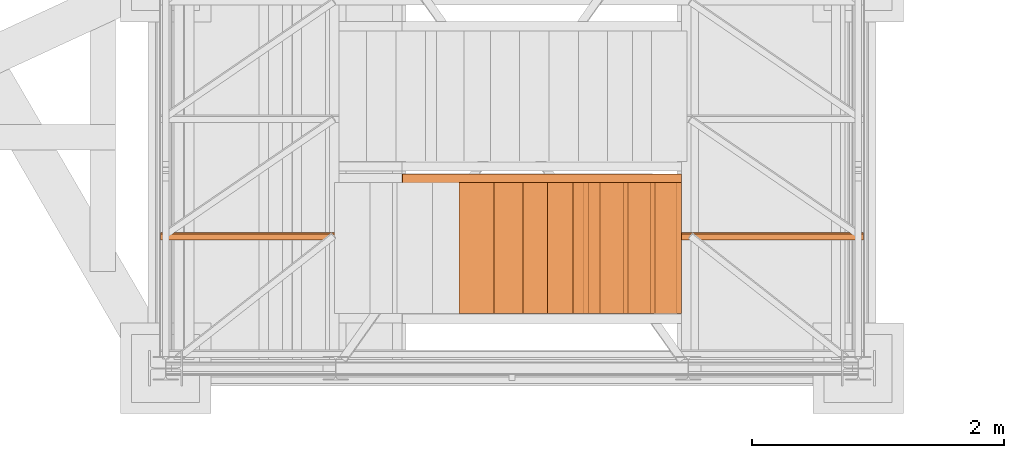
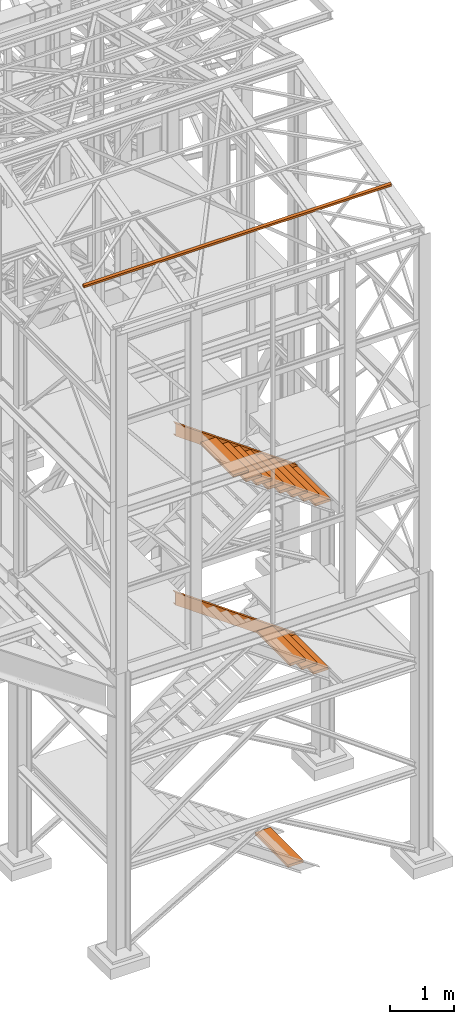
# One storey, part 46 of 208: 15 proxies.
"""IFC2X3 building model written with IfcOpenShell, lengths in millimetres."""

from ifc_helpers import new_model, entity, si_unit, converted_unit, frame, origin, origin_with_axes, place, context, subcontext, project, spatial, faceted_brep, element, save


model = new_model("IFC2X3")

# Units and contexts
model_context = context("Model", 3, precision=1e-05, world=origin())
plan_context = context("Plan", 3, precision=1e-05, world=origin())
body_context = subcontext(model_context, "Body", "Model", "MODEL_VIEW")
ifc_project = project(units=[si_unit("LENGTHUNIT", "METRE", prefix="MILLI"), converted_unit("PLANEANGLEUNIT", "DEGREE", entity("IfcPlaneAngleMeasure", 0.0174532925199433), si_unit("PLANEANGLEUNIT", "RADIAN"), dimensions=[0, 0, 0, 0, 0, 0, 0]), si_unit("AREAUNIT", "SQUARE_METRE"), si_unit("VOLUMEUNIT", "CUBIC_METRE")], contexts=[model_context, plan_context])

# Building, storey
building_placement = place(None, origin())
building = spatial("IfcBuilding", under=ifc_project, at=building_placement, CompositionType="COMPLEX")
storey_placement = place(building_placement, origin_with_axes())
storey = spatial("IfcBuildingStorey", under=building, at=storey_placement, Name="Geschoss", CompositionType="ELEMENT")

# Proxies
for number, where, z_axis, x_axis in (
    (1, (4978.136752628499, -24736.51916887601, 3613.990001490116), (0.0, 0.0, 1.0), (1.0, 0.0, 0.0)),
    (2, (4768.462616675066, -24736.51916887601, 3776.233858917962), (0.0, 0.0, 1.0), (1.0, 0.0, 0.0)),
    (3, (4554.39359251667, -24736.51916887601, 3925.104369881302), (0.0, 0.0, 1.0), (1.0, 0.0, 0.0)),
):
    element("IfcBuildingElementProxy", number, at=place(storey_placement, frame(where, z_axis=z_axis, x_axis=x_axis)), inside=storey, context=body_context, shape_type="Brep", body=[
        faceted_brep([(0.009999999999308784, 0.00999999999839929, 0.01000000000021828), (280.2746556316179, 0.00999999999839929, 0.01000000000021828), (280.2746556316179, 1037.717170711916, 0.01000000000021828), (0.009999999999308784, 1037.717170711916, 0.01000000000021828), (280.2746556316179, 0.00999999999839929, 50.01000000000022), (0.009999999999308784, 0.00999999999839929, 50.01000000000022), (0.009999999999308784, 1037.717170711916, 50.01000000000022), (280.2746556316179, 1037.717170711916, 50.01000000000022), (280.2746556316179, 0.00999999999839929, 0.01000000000021828), (0.009999999999308784, 0.00999999999839929, 0.01000000000021828), (0.009999999999308784, 0.00999999999839929, 50.01000000000022), (280.2746556316179, 0.00999999999839929, 50.01000000000022), (280.2746556316179, 1037.717170711916, 0.01000000000021828), (280.2746556316179, 0.00999999999839929, 0.01000000000021828), (280.2746556316179, 0.00999999999839929, 50.01000000000022), (280.2746556316179, 1037.717170711916, 50.01000000000022), (0.009999999999308784, 1037.717170711916, 0.01000000000021828), (280.2746556316179, 1037.717170711916, 0.01000000000021828), (280.2746556316179, 1037.717170711916, 50.01000000000022), (0.009999999999308784, 1037.717170711916, 50.01000000000022), (0.009999999999308784, 0.00999999999839929, 0.01000000000021828), (0.009999999999308784, 1037.717170711916, 0.01000000000021828), (0.009999999999308784, 1037.717170711916, 50.01000000000022), (0.009999999999308784, 0.00999999999839929, 50.01000000000022)], [[[0, 1, 2, 3]], [[4, 5, 6, 7]], [[8, 9, 10, 11]], [[12, 13, 14, 15]], [[16, 17, 18, 19]], [[20, 21, 22, 23]]], orient=[[False], [False], [False], [False], [False], [False]]),
    ])
proxy_1_placement = place(storey_placement, frame((4517.830253904742, -24736.51916887601, 69.9900010557138), z_axis=(0.0, 0.0, 1.0), x_axis=(1.0, 0.0, 0.0)))
element("IfcBuildingElementProxy", 4, at=proxy_1_placement, inside=storey, context=body_context, shape_type="Brep", body=[
    faceted_brep([(0.009999999999308784, 0.00999999999839929, 0.01000000000000512), (280.2746556316179, 0.00999999999839929, 0.01000000000000512), (280.2746556316179, 1037.717170711916, 0.01000000000000512), (0.009999999999308784, 1037.717170711916, 0.01000000000000512), (280.2746556316179, 0.00999999999839929, 50.01000000000001), (0.009999999999308784, 0.00999999999839929, 50.01000000000001), (0.009999999999308784, 1037.717170711916, 50.01000000000001), (280.2746556316179, 1037.717170711916, 50.01000000000001), (280.2746556316179, 0.00999999999839929, 0.01000000000000512), (0.009999999999308784, 0.00999999999839929, 0.01000000000000512), (0.009999999999308784, 0.00999999999839929, 50.01000000000001), (280.2746556316179, 0.00999999999839929, 50.01000000000001), (280.2746556316179, 1037.717170711916, 0.01000000000000512), (280.2746556316179, 0.00999999999839929, 0.01000000000000512), (280.2746556316179, 0.00999999999839929, 50.01000000000001), (280.2746556316179, 1037.717170711916, 50.01000000000001), (0.009999999999308784, 1037.717170711916, 0.01000000000000512), (280.2746556316179, 1037.717170711916, 0.01000000000000512), (280.2746556316179, 1037.717170711916, 50.01000000000001), (0.009999999999308784, 1037.717170711916, 50.01000000000001), (0.009999999999308784, 0.00999999999839929, 0.01000000000000512), (0.009999999999308784, 1037.717170711916, 0.01000000000000512), (0.009999999999308784, 1037.717170711916, 50.01000000000001), (0.009999999999308784, 0.00999999999839929, 50.01000000000001)], [[[0, 1, 2, 3]], [[4, 5, 6, 7]], [[8, 9, 10, 11]], [[12, 13, 14, 15]], [[16, 17, 18, 19]], [[20, 21, 22, 23]]], orient=[[False], [False], [False], [False], [False], [False]]),
])
proxy_2_placement = place(storey_placement, frame((3076.75804237704, -23702.72083116692, 6651.257815805529), z_axis=(0.0, 0.0, 1.0), x_axis=(1.0, 0.0, 0.0)))
element("IfcBuildingElementProxy", 5, at=proxy_2_placement, inside=storey, context=body_context, shape_type="Brep", body=[
    faceted_brep([(0.01000000000112777, 0.00999999999839929, 1579.178796878196), (0.01000000000112777, 0.00999999999839929, 1824.742182942768), (2216.653365883077, 0.00999999999839929, 245.5733860645723), (2216.653365883076, 0.00999999999839929, 0.01000000000021828), (0.01000000000112777, 0.00999999999839929, 1824.742182942768), (0.01000000000112777, 75.01000111758549, 1824.742182942768), (2216.653365883077, 75.01000111758549, 245.5733860645723), (2216.653365883077, 0.00999999999839929, 245.5733860645723), (0.01000000000112777, 75.01000111758549, 1824.742182942768), (0.01000000000112777, 75.01000111758549, 1821.106824657074), (2216.653365883077, 75.01000111758549, 241.9380277788805), (2216.653365883077, 75.01000111758549, 245.5733860645723), (0.01000000000112777, 75.01000111758549, 1821.106824657074), (0.01000000000021828, 73.89400100171406, 1815.706881923725), (2216.653365883077, 73.89400100171406, 236.5380850455285), (2216.653365883077, 75.01000111758549, 241.9380277788805), (0.01000000000021828, 73.89400100171406, 1815.706881923725), (0.01000000000203727, 69.488472694753, 1813.763381892239), (2216.653365883076, 69.488472694753, 234.5945850140433), (2216.653365883077, 73.89400100171406, 236.5380850455285), (0.01000000000203727, 69.488472694753, 1813.763381892239), (0.01000000000112777, 19.09293180167515, 1808.813262100295), (2216.653365883077, 19.09293180167515, 229.6444652221016), (2216.653365883076, 69.488472694753, 234.5945850140433), (0.01000000000112777, 19.09293180167515, 1808.813262100295), (0.01000000000021828, 13.35380079060633, 1806.854622213446), (2216.653365883077, 13.35380079060633, 227.6858253352511), (2216.653365883077, 19.09293180167515, 229.6444652221016), (0.01000000000021828, 13.35380079060633, 1806.854622213446), (0.01000000000112777, 9.500150026975462, 1801.599198776206), (2216.653365883077, 9.500150026975462, 222.430401898011), (2216.653365883077, 13.35380079060633, 227.6858253352511), (0.01000000000112777, 9.500150026975462, 1801.599198776206), (0.01000000000112777, 8.510000461934396, 1794.738337757652), (2216.653365883078, 8.510000461934396, 215.5695408794572), (2216.653365883077, 9.500150026975462, 222.430401898011), (0.01000000000112777, 8.510000461934396, 1794.738337757652), (0.01000000000112777, 8.510000461934396, 1609.182642063313), (2216.653365883077, 8.510000461934396, 30.01384518511804), (2216.653365883078, 8.510000461934396, 215.5695408794572), (0.01000000000112777, 8.510000461934396, 1609.182642063313), (0.01000000000203727, 9.500150026975462, 1602.321781044757), (2216.653365883077, 9.500150026975462, 23.15298416656242), (2216.653365883077, 8.510000461934396, 30.01384518511804), (0.01000000000203727, 9.500150026975462, 1602.321781044757), (0.01000000000203727, 13.35380079060633, 1597.066357607517), (2216.653365883077, 13.35380079060633, 17.89756072932232), (2216.653365883077, 9.500150026975462, 23.15298416656242), (0.01000000000203727, 13.35380079060633, 1597.066357607517), (0.01000000000203727, 19.09293180167515, 1595.107717720666), (2216.653365883077, 19.09293180167515, 15.93892084247273), (2216.653365883077, 13.35380079060633, 17.89756072932232), (0.01000000000203727, 19.09293180167515, 1595.107717720666), (0.01000000000112777, 69.488472694753, 1590.157597928728), (2216.653365883077, 69.488472694753, 10.98880105053104), (2216.653365883077, 19.09293180167515, 15.93892084247273), (0.01000000000112777, 69.488472694753, 1590.157597928728), (0.01000000000203727, 73.89400100171406, 1588.21409789724), (2216.653365883077, 73.89400100171406, 9.045301019044928), (2216.653365883077, 69.488472694753, 10.98880105053104), (0.01000000000203727, 73.89400100171406, 1588.21409789724), (0.01000000000112777, 75.01000111758549, 1582.814155163889), (2216.653365883077, 75.01000111758549, 3.645358285693874), (2216.653365883077, 73.89400100171406, 9.045301019044928), (0.01000000000112777, 75.01000111758549, 1582.814155163889), (0.01000000000112777, 75.01000111758549, 1579.178796878196), (2216.653365883077, 75.01000111758549, 0.01000000000021828), (2216.653365883077, 75.01000111758549, 3.645358285693874), (0.01000000000112777, 75.01000111758549, 1579.178796878196), (0.01000000000112777, 0.00999999999839929, 1579.178796878196), (2216.653365883076, 0.00999999999839929, 0.01000000000021828), (2216.653365883077, 75.01000111758549, 0.01000000000021828), (2216.653365883076, 0.00999999999839929, 0.01000000000021828), (2216.653365883077, 0.00999999999839929, 245.5733860645723), (2216.653365883077, 75.01000111758549, 245.5733860645723), (2216.653365883077, 75.01000111758549, 241.9380277788805), (2216.653365883077, 73.89400100171406, 236.5380850455285), (2216.653365883076, 69.488472694753, 234.5945850140433), (2216.653365883077, 19.09293180167515, 229.6444652221016), (2216.653365883077, 13.35380079060633, 227.6858253352511), (2216.653365883077, 9.500150026975462, 222.430401898011), (2216.653365883078, 8.510000461934396, 215.5695408794572), (2216.653365883077, 8.510000461934396, 30.01384518511804), (2216.653365883077, 9.500150026975462, 23.15298416656242), (2216.653365883077, 13.35380079060633, 17.89756072932232), (2216.653365883077, 19.09293180167515, 15.93892084247273), (2216.653365883077, 69.488472694753, 10.98880105053104), (2216.653365883077, 73.89400100171406, 9.045301019044928), (2216.653365883077, 75.01000111758549, 3.645358285693874), (2216.653365883077, 75.01000111758549, 0.01000000000021828), (0.01000000000112777, 0.00999999999839929, 1579.178796878196), (0.01000000000112777, 75.01000111758549, 1579.178796878196), (0.01000000000112777, 75.01000111758549, 1582.814155163889), (0.01000000000203727, 73.89400100171406, 1588.21409789724), (0.01000000000112777, 69.488472694753, 1590.157597928728), (0.01000000000203727, 19.09293180167515, 1595.107717720666), (0.01000000000203727, 13.35380079060633, 1597.066357607517), (0.01000000000203727, 9.500150026975462, 1602.321781044757), (0.01000000000112777, 8.510000461934396, 1609.182642063313), (0.01000000000112777, 8.510000461934396, 1794.738337757652), (0.01000000000112777, 9.500150026975462, 1801.599198776206), (0.01000000000021828, 13.35380079060633, 1806.854622213446), (0.01000000000112777, 19.09293180167515, 1808.813262100295), (0.01000000000203727, 69.488472694753, 1813.763381892239), (0.01000000000021828, 73.89400100171406, 1815.706881923725), (0.01000000000112777, 75.01000111758549, 1821.106824657074), (0.01000000000112777, 75.01000111758549, 1824.742182942768), (0.01000000000112777, 0.00999999999839929, 1824.742182942768)], [[[0, 1, 2, 3]], [[4, 5, 6, 7]], [[8, 9, 10, 11]], [[12, 13, 14, 15]], [[16, 17, 18, 19]], [[20, 21, 22, 23]], [[24, 25, 26, 27]], [[28, 29, 30, 31]], [[32, 33, 34, 35]], [[36, 37, 38, 39]], [[40, 41, 42, 43]], [[44, 45, 46, 47]], [[48, 49, 50, 51]], [[52, 53, 54, 55]], [[56, 57, 58, 59]], [[60, 61, 62, 63]], [[64, 65, 66, 67]], [[68, 69, 70, 71]], [[72, 73, 74, 75, 76, 77, 78, 79, 80, 81, 82, 83, 84, 85, 86, 87, 88, 89]], [[90, 91, 92, 93, 94, 95, 96, 97, 98, 99, 100, 101, 102, 103, 104, 105, 106, 107]]], orient=[[False], [False], [False], [False], [False], [False], [False], [False], [False], [False], [False], [False], [False], [False], [False], [False], [False], [False], [False], [False]]),
])
for number, where, z_axis, x_axis in (
    (6, (5013.136752628499, -24736.51916887601, 6833.952231763451), (0.0, 0.0, 1.0), (1.0, 0.0, 0.0)),
    (7, (4803.462616675064, -24736.51916887601, 6996.196089191297), (0.0, 0.0, 1.0), (1.0, 0.0, 0.0)),
    (8, (4589.39359251667, -24736.51916887601, 7145.066600154638), (0.0, 0.0, 1.0), (1.0, 0.0, 0.0)),
    (9, (4368.540323586694, -24736.51916887601, 7302.405663510832), (0.0, 0.0, 1.0), (1.0, 0.0, 0.0)),
    (10, (4152.985395275855, -24736.51916887601, 7450.570169637833), (0.0, 0.0, 1.0), (1.0, 0.0, 0.0)),
):
    element("IfcBuildingElementProxy", number, at=place(storey_placement, frame(where, z_axis=z_axis, x_axis=x_axis)), inside=storey, context=body_context, shape_type="Brep", body=[
        faceted_brep([(0.009999999999308784, 0.00999999999839929, 0.01000000000021828), (280.2746556316179, 0.00999999999839929, 0.01000000000021828), (280.2746556316179, 1037.717170711916, 0.01000000000021828), (0.009999999999308784, 1037.717170711916, 0.01000000000021828), (280.2746556316179, 0.00999999999839929, 50.01000000000022), (0.009999999999308784, 0.00999999999839929, 50.01000000000022), (0.009999999999308784, 1037.717170711916, 50.01000000000022), (280.2746556316179, 1037.717170711916, 50.01000000000022), (280.2746556316179, 0.00999999999839929, 0.01000000000021828), (0.009999999999308784, 0.00999999999839929, 0.01000000000021828), (0.009999999999308784, 0.00999999999839929, 50.01000000000022), (280.2746556316179, 0.00999999999839929, 50.01000000000022), (280.2746556316179, 1037.717170711916, 0.01000000000021828), (280.2746556316179, 0.00999999999839929, 0.01000000000021828), (280.2746556316179, 0.00999999999839929, 50.01000000000022), (280.2746556316179, 1037.717170711916, 50.01000000000022), (0.009999999999308784, 1037.717170711916, 0.01000000000021828), (280.2746556316179, 1037.717170711916, 0.01000000000021828), (280.2746556316179, 1037.717170711916, 50.01000000000022), (0.009999999999308784, 1037.717170711916, 50.01000000000022), (0.009999999999308784, 0.00999999999839929, 0.01000000000021828), (0.009999999999308784, 1037.717170711916, 0.01000000000021828), (0.009999999999308784, 1037.717170711916, 50.01000000000022), (0.009999999999308784, 0.00999999999839929, 50.01000000000022)], [[[0, 1, 2, 3]], [[4, 5, 6, 7]], [[8, 9, 10, 11]], [[12, 13, 14, 15]], [[16, 17, 18, 19]], [[20, 21, 22, 23]]], orient=[[False], [False], [False], [False], [False], [False]]),
    ])
proxy_3_placement = place(storey_placement, frame((3949.355186072306, -24736.51916887601, 7601.039218852331), z_axis=(0.0, 0.0, 1.0), x_axis=(1.0, 0.0, 0.0)))
element("IfcBuildingElementProxy", 11, at=proxy_3_placement, inside=storey, context=body_context, shape_type="Brep", body=[
    faceted_brep([(0.01000000000021828, 0.00999999999839929, 0.01000000000021828), (280.2746556316188, 0.00999999999839929, 0.01000000000021828), (280.2746556316188, 1037.717170711916, 0.01000000000021828), (0.01000000000021828, 1037.717170711916, 0.01000000000021828), (280.2746556316188, 0.00999999999839929, 50.01000000000022), (0.01000000000021828, 0.00999999999839929, 50.01000000000022), (0.01000000000021828, 1037.717170711916, 50.01000000000022), (280.2746556316188, 1037.717170711916, 50.01000000000022), (280.2746556316188, 0.00999999999839929, 0.01000000000021828), (0.01000000000021828, 0.00999999999839929, 0.01000000000021828), (0.01000000000021828, 0.00999999999839929, 50.01000000000022), (280.2746556316188, 0.00999999999839929, 50.01000000000022), (280.2746556316188, 1037.717170711916, 0.01000000000021828), (280.2746556316188, 0.00999999999839929, 0.01000000000021828), (280.2746556316188, 0.00999999999839929, 50.01000000000022), (280.2746556316188, 1037.717170711916, 50.01000000000022), (0.01000000000021828, 1037.717170711916, 0.01000000000021828), (280.2746556316188, 1037.717170711916, 0.01000000000021828), (280.2746556316188, 1037.717170711916, 50.01000000000022), (0.01000000000021828, 1037.717170711916, 50.01000000000022), (0.01000000000021828, 0.00999999999839929, 0.01000000000021828), (0.01000000000021828, 1037.717170711916, 0.01000000000021828), (0.01000000000021828, 1037.717170711916, 50.01000000000022), (0.01000000000021828, 0.00999999999839929, 50.01000000000022)], [[[0, 1, 2, 3]], [[4, 5, 6, 7]], [[8, 9, 10, 11]], [[12, 13, 14, 15]], [[16, 17, 18, 19]], [[20, 21, 22, 23]]], orient=[[False], [False], [False], [False], [False], [False]]),
])
for number, where, z_axis, x_axis in (
    (12, (3757.013833371407, -24736.51916887601, 7738.065980671367), (0.0, 0.0, 1.0), (1.0, 0.0, 0.0)),
    (13, (3525.829763493463, -24736.51916887601, 7906.400214340252), (0.0, 0.0, 1.0), (1.0, 0.0, 0.0)),
):
    element("IfcBuildingElementProxy", number, at=place(storey_placement, frame(where, z_axis=z_axis, x_axis=x_axis)), inside=storey, context=body_context, shape_type="Brep", body=[
        faceted_brep([(0.01000000000021828, 0.00999999999839929, 0.01000000000021828), (280.2746556316183, 0.00999999999839929, 0.01000000000021828), (280.2746556316183, 1037.717170711916, 0.01000000000021828), (0.01000000000021828, 1037.717170711916, 0.01000000000021828), (280.2746556316183, 0.00999999999839929, 50.01000000000022), (0.01000000000021828, 0.00999999999839929, 50.01000000000022), (0.01000000000021828, 1037.717170711916, 50.01000000000022), (280.2746556316183, 1037.717170711916, 50.01000000000022), (280.2746556316183, 0.00999999999839929, 0.01000000000021828), (0.01000000000021828, 0.00999999999839929, 0.01000000000021828), (0.01000000000021828, 0.00999999999839929, 50.01000000000022), (280.2746556316183, 0.00999999999839929, 50.01000000000022), (280.2746556316183, 1037.717170711916, 0.01000000000021828), (280.2746556316183, 0.00999999999839929, 0.01000000000021828), (280.2746556316183, 0.00999999999839929, 50.01000000000022), (280.2746556316183, 1037.717170711916, 50.01000000000022), (0.01000000000021828, 1037.717170711916, 0.01000000000021828), (280.2746556316183, 1037.717170711916, 0.01000000000021828), (280.2746556316183, 1037.717170711916, 50.01000000000022), (0.01000000000021828, 1037.717170711916, 50.01000000000022), (0.01000000000021828, 0.00999999999839929, 0.01000000000021828), (0.01000000000021828, 1037.717170711916, 0.01000000000021828), (0.01000000000021828, 1037.717170711916, 50.01000000000022), (0.01000000000021828, 0.00999999999839929, 50.01000000000022)], [[[0, 1, 2, 3]], [[4, 5, 6, 7]], [[8, 9, 10, 11]], [[12, 13, 14, 15]], [[16, 17, 18, 19]], [[20, 21, 22, 23]]], orient=[[False], [False], [False], [False], [False], [False]]),
    ])
proxy_4_placement = place(storey_placement, frame((1157.254971121462, -24154.67201634085, 12012.25196565828), z_axis=(0.0, 0.0, 1.0), x_axis=(1.0, 0.0, 0.0)))
element("IfcBuildingElementProxy", 14, at=proxy_4_placement, inside=storey, context=body_context, shape_type="Brep", body=[
    faceted_brep([(5582.010002264974, 48.59909357395372, 60.39315927079406), (5582.010002264974, 60.39315927079224, 11.80406569683692), (5582.010002264974, 11.80406569683692, 0.00999999999839929), (5582.010002264974, 0.00999999999839929, 48.59909357395554), (0.01000000000021828, 0.00999999999839929, 48.59909357395554), (0.01000000000021828, 11.80406569683692, 0.00999999999839929), (0.01000000000021828, 60.39315927079224, 11.80406569683692), (0.01000000000021828, 48.59909357395372, 60.39315927079406), (5582.010002264974, 0.00999999999839929, 48.59909357395554), (0.01000000000021828, 0.00999999999839929, 48.59909357395554), (0.01000000000021828, 48.59909357395372, 60.39315927079406), (5582.010002264974, 48.59909357395372, 60.39315927079406), (5582.010002264974, 11.80406569683692, 0.00999999999839929), (0.01000000000021828, 11.80406569683692, 0.00999999999839929), (0.01000000000021828, 0.00999999999839929, 48.59909357395554), (5582.010002264974, 0.00999999999839929, 48.59909357395554), (5582.010002264974, 60.39315927079224, 11.80406569683692), (0.01000000000021828, 60.39315927079224, 11.80406569683692), (0.01000000000021828, 11.80406569683692, 0.00999999999839929), (5582.010002264974, 11.80406569683692, 0.00999999999839929), (5582.010002264974, 48.59909357395372, 60.39315927079406), (0.01000000000021828, 48.59909357395372, 60.39315927079406), (0.01000000000021828, 60.39315927079224, 11.80406569683692), (5582.010002264974, 60.39315927079224, 11.80406569683692)], [[[0, 1, 2, 3]], [[4, 5, 6, 7]], [[8, 9, 10, 11]], [[12, 13, 14, 15]], [[16, 17, 18, 19]], [[20, 21, 22, 23]]], orient=[[False], [False], [False], [False], [False], [False]]),
])
proxy_5_placement = place(storey_placement, frame((3073.108528797206, -23702.72083116692, 3431.295585532194), z_axis=(0.0, 0.0, 1.0), x_axis=(1.0, 0.0, 0.0)))
element("IfcBuildingElementProxy", 15, at=proxy_5_placement, inside=storey, context=body_context, shape_type="Brep", body=[
    faceted_brep([(0.01000000000112777, 0.00999999999839929, 1556.844256877909), (0.01000000000112777, 0.00999999999839929, 1802.407642942482), (2185.302879462911, 0.00999999999839929, 245.5733860645723), (2185.302879462911, 0.00999999999839929, 0.009999999999763531), (0.01000000000112777, 0.00999999999839929, 1802.407642942482), (0.01000000000112777, 75.01000111758549, 1802.407642942482), (2185.302879462911, 75.01000111758549, 245.5733860645723), (2185.302879462911, 0.00999999999839929, 245.5733860645723), (0.01000000000112777, 75.01000111758549, 1802.407642942482), (0.01000000000112777, 75.01000111758549, 1798.772284656788), (2185.302879462911, 75.01000111758549, 241.9380277788796), (2185.302879462911, 75.01000111758549, 245.5733860645723), (0.01000000000112777, 75.01000111758549, 1798.772284656788), (0.01000000000021828, 73.89400100171406, 1793.372341923438), (2185.302879462911, 73.89400100171406, 236.5380850455281), (2185.302879462911, 75.01000111758549, 241.9380277788796), (0.01000000000021828, 73.89400100171406, 1793.372341923438), (0.01000000000203727, 69.488472694753, 1791.428841891953), (2185.302879462911, 69.488472694753, 234.5945850140429), (2185.302879462911, 73.89400100171406, 236.5380850455281), (0.01000000000203727, 69.488472694753, 1791.428841891953), (0.01000000000112777, 19.09293180167515, 1786.47872210001), (2185.302879462911, 19.09293180167515, 229.6444652221012), (2185.302879462911, 69.488472694753, 234.5945850140429), (0.01000000000112777, 19.09293180167515, 1786.47872210001), (0.01000000000021828, 13.35380079060633, 1784.52008221316), (2185.302879462911, 13.35380079060633, 227.6858253352502), (2185.302879462911, 19.09293180167515, 229.6444652221012), (0.01000000000021828, 13.35380079060633, 1784.52008221316), (0.01000000000112777, 9.500150026975462, 1779.26465877592), (2185.302879462911, 9.500150026975462, 222.4304018980101), (2185.302879462911, 13.35380079060633, 227.6858253352502), (0.01000000000112777, 9.500150026975462, 1779.26465877592), (0.01000000000112777, 8.510000461934396, 1772.403797757366), (2185.302879462911, 8.510000461934396, 215.5695408794568), (2185.302879462911, 9.500150026975462, 222.4304018980101), (0.01000000000112777, 8.510000461934396, 1772.403797757366), (0.01000000000112777, 8.510000461934396, 1586.848102063028), (2185.302879462911, 8.510000461934396, 30.01384518511804), (2185.302879462911, 8.510000461934396, 215.5695408794568), (0.01000000000112777, 8.510000461934396, 1586.848102063028), (0.01000000000203727, 9.500150026975462, 1579.987241044471), (2185.302879462911, 9.500150026975462, 23.15298416656196), (2185.302879462911, 8.510000461934396, 30.01384518511804), (0.01000000000203727, 9.500150026975462, 1579.987241044471), (0.01000000000203727, 13.35380079060633, 1574.731817607231), (2185.302879462911, 13.35380079060633, 17.89756072932187), (2185.302879462911, 9.500150026975462, 23.15298416656196), (0.01000000000203727, 13.35380079060633, 1574.731817607231), (0.01000000000203727, 19.09293180167515, 1572.773177720381), (2185.302879462911, 19.09293180167515, 15.93892084247227), (2185.302879462911, 13.35380079060633, 17.89756072932187), (0.01000000000203727, 19.09293180167515, 1572.773177720381), (0.01000000000112777, 69.488472694753, 1567.823057928442), (2185.302879462911, 69.488472694753, 10.98880105053104), (2185.302879462911, 19.09293180167515, 15.93892084247227), (0.01000000000112777, 69.488472694753, 1567.823057928442), (0.01000000000203727, 73.89400100171406, 1565.879557896955), (2185.302879462911, 73.89400100171406, 9.045301019044473), (2185.302879462911, 69.488472694753, 10.98880105053104), (0.01000000000203727, 73.89400100171406, 1565.879557896955), (0.01000000000112777, 75.01000111758549, 1560.479615163604), (2185.302879462911, 75.01000111758549, 3.645358285693874), (2185.302879462911, 73.89400100171406, 9.045301019044473), (0.01000000000112777, 75.01000111758549, 1560.479615163604), (0.01000000000112777, 75.01000111758549, 1556.844256877909), (2185.302879462911, 75.01000111758549, 0.009999999999763531), (2185.302879462911, 75.01000111758549, 3.645358285693874), (0.01000000000112777, 75.01000111758549, 1556.844256877909), (0.01000000000112777, 0.00999999999839929, 1556.844256877909), (2185.302879462911, 0.00999999999839929, 0.009999999999763531), (2185.302879462911, 75.01000111758549, 0.009999999999763531), (2185.302879462911, 0.00999999999839929, 0.009999999999763531), (2185.302879462911, 0.00999999999839929, 245.5733860645723), (2185.302879462911, 75.01000111758549, 245.5733860645723), (2185.302879462911, 75.01000111758549, 241.9380277788796), (2185.302879462911, 73.89400100171406, 236.5380850455281), (2185.302879462911, 69.488472694753, 234.5945850140429), (2185.302879462911, 19.09293180167515, 229.6444652221012), (2185.302879462911, 13.35380079060633, 227.6858253352502), (2185.302879462911, 9.500150026975462, 222.4304018980101), (2185.302879462911, 8.510000461934396, 215.5695408794568), (2185.302879462911, 8.510000461934396, 30.01384518511804), (2185.302879462911, 9.500150026975462, 23.15298416656196), (2185.302879462911, 13.35380079060633, 17.89756072932187), (2185.302879462911, 19.09293180167515, 15.93892084247227), (2185.302879462911, 69.488472694753, 10.98880105053104), (2185.302879462911, 73.89400100171406, 9.045301019044473), (2185.302879462911, 75.01000111758549, 3.645358285693874), (2185.302879462911, 75.01000111758549, 0.009999999999763531), (0.01000000000112777, 0.00999999999839929, 1556.844256877909), (0.01000000000112777, 75.01000111758549, 1556.844256877909), (0.01000000000112777, 75.01000111758549, 1560.479615163604), (0.01000000000203727, 73.89400100171406, 1565.879557896955), (0.01000000000112777, 69.488472694753, 1567.823057928442), (0.01000000000203727, 19.09293180167515, 1572.773177720381), (0.01000000000203727, 13.35380079060633, 1574.731817607231), (0.01000000000203727, 9.500150026975462, 1579.987241044471), (0.01000000000112777, 8.510000461934396, 1586.848102063028), (0.01000000000112777, 8.510000461934396, 1772.403797757366), (0.01000000000112777, 9.500150026975462, 1779.26465877592), (0.01000000000021828, 13.35380079060633, 1784.52008221316), (0.01000000000112777, 19.09293180167515, 1786.47872210001), (0.01000000000203727, 69.488472694753, 1791.428841891953), (0.01000000000021828, 73.89400100171406, 1793.372341923438), (0.01000000000112777, 75.01000111758549, 1798.772284656788), (0.01000000000112777, 75.01000111758549, 1802.407642942482), (0.01000000000112777, 0.00999999999839929, 1802.407642942482)], [[[0, 1, 2, 3]], [[4, 5, 6, 7]], [[8, 9, 10, 11]], [[12, 13, 14, 15]], [[16, 17, 18, 19]], [[20, 21, 22, 23]], [[24, 25, 26, 27]], [[28, 29, 30, 31]], [[32, 33, 34, 35]], [[36, 37, 38, 39]], [[40, 41, 42, 43]], [[44, 45, 46, 47]], [[48, 49, 50, 51]], [[52, 53, 54, 55]], [[56, 57, 58, 59]], [[60, 61, 62, 63]], [[64, 65, 66, 67]], [[68, 69, 70, 71]], [[72, 73, 74, 75, 76, 77, 78, 79, 80, 81, 82, 83, 84, 85, 86, 87, 88, 89]], [[90, 91, 92, 93, 94, 95, 96, 97, 98, 99, 100, 101, 102, 103, 104, 105, 106, 107]]], orient=[[False], [False], [False], [False], [False], [False], [False], [False], [False], [False], [False], [False], [False], [False], [False], [False], [False], [False], [False], [False]]),
])

save(model, "model.ifc")
